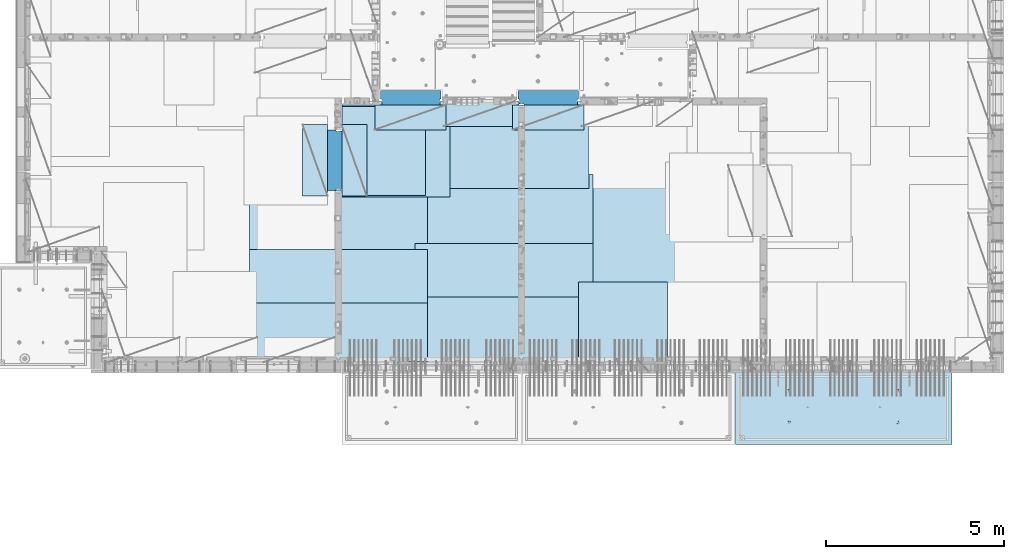
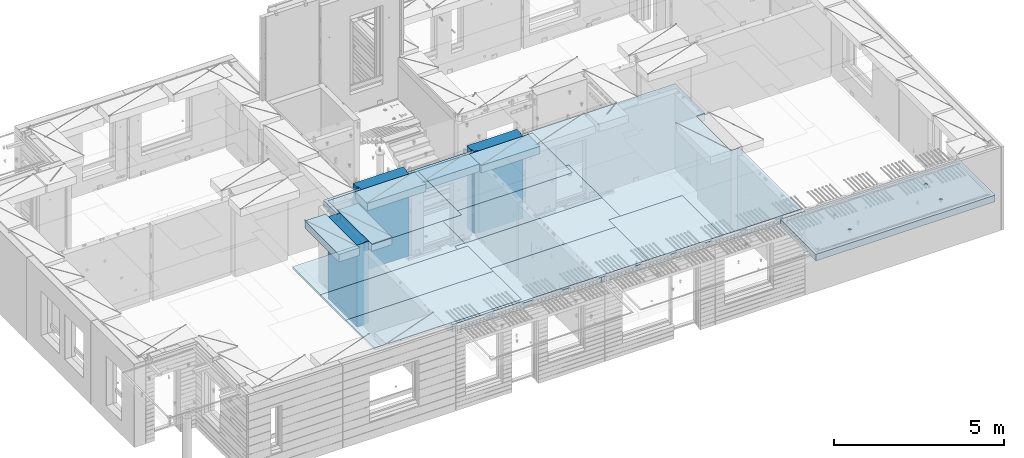
# One storey, part 202 of 352: 18 plates, 3 slabs, 19 elements without a shape of their own.
"""IFC2X3 building model written with IfcOpenShell, lengths in millimetres."""

import ifcopenshell
import ifcopenshell.guid

model = None  # the IFC model being written
_history = None  # IfcOwnerHistory: only IFC2X3 demands one
_inside = {}  # id of a spatial element -> (the spatial element, [elements in it])
_under = {}  # id of a project, library or spatial element -> (it, [spatial elements below it])
_declared = {}  # id of a project -> (the project, [libraries it declares])
_typed = {}  # id of a type object -> (the type object, [elements of that type])
_made_of = {}  # id of a material, layer set ... -> (it, [elements and type objects made of it])


def new_model(schema):
    """Start an empty IFC model of exactly this schema.

    Asked for "IFC4X3", IfcOpenShell would pick the latest addendum, in which some entities
    have other attributes; the version numbers below select the first issue.
    IFC2X3 requires an IfcOwnerHistory on every rooted entity: one is made here for all.
    """
    global model, _history
    if schema == "IFC4X3":
        model = ifcopenshell.file(schema_version=(4, 3, 0, 0))
    else:
        model = ifcopenshell.file(schema=schema)
    _inside.clear()
    _under.clear()
    _declared.clear()
    _typed.clear()
    _made_of.clear()
    _history = None
    if model.schema == "IFC2X3":
        org = make("IfcOrganization", Name="unknown")
        user = make(
            "IfcPersonAndOrganization",
            ThePerson=make("IfcPerson", FamilyName="unknown"),
            TheOrganization=org,
        )
        app = make(
            "IfcApplication",
            ApplicationDeveloper=org,
            Version="unknown",
            ApplicationFullName="unknown",
            ApplicationIdentifier="unknown",
        )
        _history = make(
            "IfcOwnerHistory",
            OwningUser=user,
            OwningApplication=app,
            ChangeAction="ADDED",
            CreationDate=0,
        )
    return model


def make(cls, **values):
    """One entity of the class cls with the attributes given. An attribute that is None is left unset."""
    return model.create_entity(
        cls, **{name: value for name, value in values.items() if value is not None}
    )


def rooted(cls, **values):
    """An entity with a GlobalId (a new one), such as an element, a storey or a relation."""
    return make(cls, GlobalId=ifcopenshell.guid.new(), OwnerHistory=_history, **values)


def si_unit(unit_type, name, prefix=None):
    """IfcSIUnit, for example si_unit("LENGTHUNIT", "METRE", prefix="MILLI")."""
    return make("IfcSIUnit", UnitType=unit_type, Prefix=prefix, Name=name)


def assignment(units):
    """IfcUnitAssignment: the units of a project."""
    return None if units is None else make("IfcUnitAssignment", Units=units)


def point(xyz):
    """IfcCartesianPoint."""
    return None if xyz is None else make("IfcCartesianPoint", Coordinates=xyz)


def direction(xyz):
    """IfcDirection."""
    return None if xyz is None else make("IfcDirection", DirectionRatios=xyz)


def frame(location, z_axis=None, x_axis=None):
    """IfcAxis2Placement3D, a coordinate frame: its origin and axes. An axis left out is left unset."""
    return make(
        "IfcAxis2Placement3D",
        Location=point(location),
        Axis=direction(z_axis),
        RefDirection=direction(x_axis),
    )


def origin_with_axes():
    """The frame at (0, 0, 0) with the z axis (0, 0, 1) and the x axis (1, 0, 0) written out."""
    return frame((0.0, 0.0, 0.0), z_axis=(0.0, 0.0, 1.0), x_axis=(1.0, 0.0, 0.0))


def place(relative_to, where):
    """IfcLocalPlacement: puts the frame where relative to a parent placement (None: the world)."""
    return make(
        "IfcLocalPlacement", PlacementRelTo=relative_to, RelativePlacement=where
    )


def context(
    kind, dimensions, precision=None, world=None, true_north=None, identifier=None
):
    """IfcGeometricRepresentationContext, for example the 3D "Model" context."""
    return make(
        "IfcGeometricRepresentationContext",
        ContextIdentifier=identifier,
        ContextType=kind,
        CoordinateSpaceDimension=dimensions,
        Precision=precision,
        WorldCoordinateSystem=world,
        TrueNorth=true_north,
    )


def subcontext(parent, identifier, kind, view, scale=None):
    """IfcGeometricRepresentationSubContext, for example "Body" below "Model"."""
    return make(
        "IfcGeometricRepresentationSubContext",
        ContextIdentifier=identifier,
        ContextType=kind,
        ParentContext=parent,
        TargetScale=scale,
        TargetView=view,
    )


def project(units=None, contexts=None):
    """IfcProject with its units and contexts."""
    return rooted(
        "IfcProject",
        Name="project",
        RepresentationContexts=contexts,
        UnitsInContext=assignment(units),
    )


def spatial(cls, under=None, at=None, **own):
    """A site, building, storey or space (cls), placed at a placement, below another one or the project."""
    s = rooted(cls, ObjectPlacement=at, **own)
    if under is not None:
        _under.setdefault(under.id(), (under, []))[1].append(s)
    return s


def faces_of(points, faces, orient=None, outer=None):
    """IfcFace entities. A face is a list of loops; a loop is a list of indices into points, from 0.

    orient and outer hold one flag for each loop. By default every Orientation is true, the
    first loop of a face is its IfcFaceOuterBound and the others are IfcFaceBound.
    """
    made = []
    for i, loops in enumerate(faces):
        bounds = []
        for j, loop in enumerate(loops):
            is_outer = j == 0 if outer is None else outer[i][j]
            bounds.append(
                make(
                    "IfcFaceOuterBound" if is_outer else "IfcFaceBound",
                    Bound=make("IfcPolyLoop", Polygon=[points[k] for k in loop]),
                    Orientation=True if orient is None else orient[i][j],
                )
            )
        made.append(make("IfcFace", Bounds=bounds))
    return made


def faceted_brep(points, faces, orient=None, outer=None, voids=None):
    """IfcFacetedBrep: a solid bounded by flat faces; with voids (closed shells), ...WithVoids."""
    shared = [point(p) for p in points]
    hull = make("IfcClosedShell", CfsFaces=faces_of(shared, faces, orient, outer))
    if voids is None:
        return make("IfcFacetedBrep", Outer=hull)
    return make(
        "IfcFacetedBrepWithVoids",
        Outer=hull,
        Voids=[
            make(cls, CfsFaces=faces_of(shared, fs, o, b)) for cls, fs, o, b in voids
        ],
    )


def shape(context_of_items, identifier, shape_type, items):
    """IfcShapeRepresentation: the items that make up one representation, for example the "Body"."""
    return make(
        "IfcShapeRepresentation",
        ContextOfItems=context_of_items,
        RepresentationIdentifier=identifier,
        RepresentationType=shape_type,
        Items=items,
    )


def material(Name=None, Category=None):
    """IfcMaterial."""
    return make("IfcMaterial", Name=Name, Category=Category)


def made_of(thing, what):
    """Note that an element or type object is made of a material, layer set ...; save() writes the relation."""
    if what is not None:
        _made_of.setdefault(what.id(), (what, []))[1].append(thing)
    return thing


def type_object(cls, material=None, **own):
    """A type object (cls), such as IfcWallType, which elements share."""
    return made_of(rooted(cls, **own), material)


def element(
    cls,
    number,
    at=None,
    inside=None,
    cuts=None,
    type_object=None,
    material=None,
    context=None,
    identifier="Body",
    shape_type=None,
    held_by="IfcProductDefinitionShape",
    body=None,
    shapes=None,
    **own,
):
    """One element of the class cls, such as IfcWall. Its Tag is "e" and its number.

    at: its placement. inside: the storey or other place that contains it. cuts: it is an
    opening in that element (IfcRelVoidsElement). A single representation is given by context,
    identifier, shape_type and body (its items); several are given by shapes. held_by: the class
    of the entity that holds the representations. save() writes the other relations.
    """
    e = rooted(cls, Tag="e%d" % number, ObjectPlacement=at, **own)
    if body is not None:
        shapes = [shape(context, identifier, shape_type, body)]
    if shapes is not None:
        e.Representation = make(held_by, Representations=shapes)
    if inside is not None:
        _inside.setdefault(inside.id(), (inside, []))[1].append(e)
    if cuts is not None:
        rooted(
            "IfcRelVoidsElement", RelatingBuildingElement=cuts, RelatedOpeningElement=e
        )
    if type_object is not None:
        _typed.setdefault(type_object.id(), (type_object, []))[1].append(e)
    return made_of(e, material)


def aggregate(whole, parts):
    """IfcRelAggregates: a whole, such as a stair, and the parts it consists of."""
    return rooted("IfcRelAggregates", RelatingObject=whole, RelatedObjects=parts)


def save(model, path):
    """Write the relations noted so far, then the file.

    IfcRelAggregates (storeys below a building ...), IfcRelContainedInSpatialStructure (elements
    in a storey), IfcRelDefinesByType, IfcRelAssociatesMaterial and IfcRelDeclares: one each for
    every whole, place, type object, material and project.
    """
    for whole, parts in _under.values():
        aggregate(whole, parts)
    for where, things in _inside.values():
        rooted(
            "IfcRelContainedInSpatialStructure",
            RelatedElements=things,
            RelatingStructure=where,
        )
    for kind, things in _typed.values():
        rooted("IfcRelDefinesByType", RelatedObjects=things, RelatingType=kind)
    for what, things in _made_of.values():
        rooted("IfcRelAssociatesMaterial", RelatedObjects=things, RelatingMaterial=what)
    for by, libraries in _declared.values():
        rooted("IfcRelDeclares", RelatingContext=by, RelatedDefinitions=libraries)
    model.write(path)


model = new_model("IFC2X3")

# Units and contexts
model_context = context("Model", 3, precision=1e-05, world=origin_with_axes())
body_context = subcontext(model_context, "Body", "Model", "MODEL_VIEW")
ifc_project = project(units=[si_unit("LENGTHUNIT", "METRE", prefix="MILLI"), si_unit("AREAUNIT", "SQUARE_METRE"), si_unit("VOLUMEUNIT", "CUBIC_METRE"), si_unit("MASSUNIT", "GRAM", prefix="KILO"), si_unit("TIMEUNIT", "SECOND"), si_unit("PLANEANGLEUNIT", "RADIAN"), si_unit("SOLIDANGLEUNIT", "STERADIAN"), si_unit("THERMODYNAMICTEMPERATUREUNIT", "DEGREE_CELSIUS"), si_unit("LUMINOUSINTENSITYUNIT", "LUMEN")], contexts=[model_context])

# Site, building, storey
site_placement = place(None, origin_with_axes())
site = spatial("IfcSite", under=ifc_project, at=site_placement, CompositionType="ELEMENT")
building_placement = place(site_placement, origin_with_axes())
building = spatial("IfcBuilding", under=site, at=building_placement, CompositionType="ELEMENT")
storey_placement = place(building_placement, origin_with_axes())
storey = spatial("IfcBuildingStorey", under=building, at=storey_placement, Name="6", CompositionType="ELEMENT", Elevation=0.0)

# Assembly, slab
assembly_1_placement = place(storey_placement, origin_with_axes())
assembly_1 = element("IfcElementAssembly", 1, at=assembly_1_placement, inside=storey, AssemblyPlace="NOTDEFINED", PredefinedType="REINFORCEMENT_UNIT")
ifc_material_1 = material(Name="CONCRETE/C30/37")
slab_type_1 = type_object("IfcSlabType", PredefinedType="NOTDEFINED")
slab_1_placement = place(assembly_1_placement, frame((21810.0, 7750.0, 99595.0), z_axis=(0.0, 1.0, 0.0), x_axis=(1.0, 0.0, 0.0)))
slab_1 = element("IfcSlab", 2, at=slab_1_placement, type_object=slab_type_1, material=ifc_material_1, PredefinedType="FLOOR", context=body_context, shape_type="Brep", body=[
    faceted_brep([(6500.0, -135.0, 5637.99963378906), (6500.0, 135.0, 5637.99963378906), (6500.0, 135.0, 5680.0), (6500.0, -135.0, 5680.0), (6800.0, -135.0, 5680.0), (6800.0, 135.0, 5680.0), (6800.0, -135.0, 3637.99963378906), (6800.0, 135.0, 3637.99963378906), (6500.0, 135.0, 3637.99963378906), (6500.0, -135.0, 3637.99963378906), (6800.0, -135.0, 0.0), (6800.0, 135.0, 0.0), (1.81898940354586e-12, -135.0, 1.81898940354586e-12), (1.81898940354586e-12, 135.0, 1.81898940354586e-12), (0.0, -135.0, 7330.0), (0.0, 135.0, 7330.0), (1569.99914550782, -135.0, 7330.0), (1569.99914550782, 135.0, 7330.0), (1569.99914550782, -135.0, 7430.0), (1569.99914550782, 135.0, 7430.0), (6800.0, -135.0, 7430.0), (6800.0, 135.0, 7430.0), (6500.0, 135.0, 3780.0), (6500.0, -135.0, 3780.0)], [[[0, 1, 2, 3]], [[4, 3, 2, 5]], [[6, 7, 8, 9]], [[10, 11, 7, 6]], [[10, 12, 13, 11]], [[12, 14, 15, 13]], [[16, 17, 15, 14]], [[18, 19, 17, 16]], [[20, 21, 19, 18]], [[21, 20, 4, 5]], [[1, 22, 8, 7, 11, 13, 15, 17, 19, 21, 5, 2]], [[23, 9, 8, 22, 1, 0]], [[20, 18, 16, 14, 12, 10, 6, 9, 23, 0, 3, 4]]]),
])

assembly_2_placement = place(storey_placement, origin_with_axes())
assembly_2 = element("IfcElementAssembly", 3, at=assembly_2_placement, inside=storey, AssemblyPlace="NOTDEFINED", PredefinedType="REINFORCEMENT_UNIT")
ifc_material_2 = material(Name="CONCRETE/C35/45")
slab_type_2 = type_object("IfcSlabType", PredefinedType="NOTDEFINED")
slab_2_placement = place(assembly_2_placement, frame((33909.9998568133, 7629.99655735226, 99590.0), z_axis=(-1.11800000013248e-06, -0.999999999999375, 0.0), x_axis=(-0.999999999999093, 1.34699999998405e-06, 0.0)))
slab_2 = element("IfcSlab", 4, at=slab_2_placement, type_object=slab_type_2, material=ifc_material_2, PredefinedType="FLOOR", context=body_context, shape_type="Brep", body=[
    faceted_brep([(4605.44993885855, -113.0, 552.448239707288), (4619.38834372919, -113.0, 559.550231553701), (4630.44991833371, -113.0, 570.61183115741), (4637.55187867931, -113.0, 584.55025207851), (4639.99903540509, -113.0, 600.001104562554), (4637.55184376039, -113.0, 615.451951515985), (4630.44985191398, -113.0, 629.39035638662), (4619.38825231027, -113.0, 640.451930991143), (4605.44983138917, -113.0, 647.553891336743), (4589.99897890513, -113.0, 650.001048062522), (4574.54813195169, -113.0, 647.553856417822), (4560.60972708106, -113.0, 640.451864571409), (4549.54815247653, -113.0, 629.390264967699), (4542.44619213093, -113.0, 615.451844046599), (4539.99903540516, -113.0, 600.000991562554), (4542.44622704986, -113.0, 584.550144609124), (4549.54821889627, -113.0, 570.61173973849), (4560.60981849998, -113.0, 559.550165133966), (4574.54823942108, -113.0, 552.448204788368), (4589.99909190512, -113.0, 550.001048062586), (4548.90468317908, -120.0, 570.144182560607), (4541.68970509875, -120.0, 584.304334781456), (4560.14226277649, -120.0, 558.906628360102), (4574.30243130315, -120.0, 551.691682281732), (4589.99909280399, -120.0, 549.205593517132), (4605.69574868622, -120.0, 551.691717756181), (4619.85590090707, -120.0, 558.906695836513), (4631.09345510757, -120.0, 570.14427543392), (4638.30840118594, -120.0, 584.304443960583), (4640.79448995055, -120.0, 600.001105461418), (4638.30836571149, -120.0, 615.697761343653), (4631.09338763116, -120.0, 629.857913564502), (4619.85580803376, -120.0, 641.095467765007), (4605.6956395071, -120.0, 648.310413843377), (4589.99897800626, -120.0, 650.796502607977), (4574.30232212402, -120.0, 648.310378368928), (4560.14216990317, -120.0, 641.095400288596), (4548.90461570267, -120.0, 629.85782069119), (4541.6896696243, -120.0, 615.697652164527), (4539.2035808597, -120.0, 600.000990663691), (0.000819232023786753, -120.0, 2085.00366210938), (6090.0009765625, -120.0, 2085.00366210938), (6090.0009765625, 120.0, 2085.00366210938), (0.000819232023786753, 120.0, 2085.00366210938), (6090.0, -120.0, 1.39971234602854e-09), (6090.0, 120.0, 1.39971234602854e-09), (-7.27595761418343e-12, -120.0, -9.09494701772928e-13), (-7.27595761418343e-12, 120.0, -9.09494701772928e-13), (1515.44893888152, -108.0, 1437.45474794476), (1529.38734375216, -108.0, 1444.55673979117), (1540.44891835668, -108.0, 1455.61833939488), (1547.55087870228, -108.0, 1469.55676031598), (1549.99803542806, -108.0, 1485.00761280002), (1547.55084378336, -108.0, 1500.45845975345), (1540.44885193695, -108.0, 1514.39686462409), (1529.38725233324, -108.0, 1525.45843922861), (1515.44883141214, -108.0, 1532.56039957421), (1499.99797892809, -108.0, 1535.00755629999), (1484.54713197466, -108.0, 1532.56036465529), (1470.60872710403, -108.0, 1525.45837280888), (1459.5471524995, -108.0, 1514.39677320517), (1452.44519215391, -108.0, 1500.45835228407), (1449.99803542813, -108.0, 1485.00749980002), (1452.44522707283, -108.0, 1469.55665284659), (1459.54721891924, -108.0, 1455.61824797596), (1470.60881852295, -108.0, 1444.55667337144), (1484.54723944405, -108.0, 1437.45471302584), (1499.99809192809, -108.0, 1435.00755630005), (1451.1483322995, -120.0, 1469.13526457059), (1448.63439906449, -120.0, 1485.00749825911), (1458.44401483263, -120.0, 1454.8167213853), (1469.80729442553, -120.0, 1443.45346747338), (1484.12585409903, -120.0, 1436.15781730018), (1499.998093469, -120.0, 1433.64391993642), (1515.87032715753, -120.0, 1436.15785317143), (1530.18887034281, -120.0, 1443.45353570456), (1541.55212425473, -120.0, 1454.81681529746), (1548.84777442794, -120.0, 1469.13537497096), (1551.3616717917, -120.0, 1485.00761434093), (1548.84773855669, -120.0, 1500.87984802946), (1541.55205602355, -120.0, 1515.19839121474), (1530.18877643065, -120.0, 1526.56164512666), (1515.87021675716, -120.0, 1533.85729529987), (1499.99797738718, -120.0, 1536.37119266363), (1484.12574369866, -120.0, 1533.85725942862), (1469.80720051337, -120.0, 1526.56157689548), (1458.44394660145, -120.0, 1515.19829730258), (1451.14829642824, -120.0, 1500.87973762909), (1515.44993893152, -113.0, 552.45474794532), (1529.38834380215, -113.0, 559.556739791733), (1540.44991840668, -113.0, 570.618339395443), (1547.55187875228, -113.0, 584.556760316543), (1549.99903547806, -113.0, 600.007612800588), (1547.55184383336, -113.0, 615.458459754018), (1540.44985198694, -113.0, 629.396864624653), (1529.38825238323, -113.0, 640.458439229175), (1515.44983146213, -113.0, 647.560399574775), (1499.99897897809, -113.0, 650.007556300556), (1484.54813202466, -113.0, 647.560364655855), (1470.60972715402, -113.0, 640.458372809442), (1459.5481525495, -113.0, 629.396773205733), (1452.4461922039, -113.0, 615.458352284632), (1449.99903547812, -113.0, 600.007499800588), (1452.44622712283, -113.0, 584.556652847157), (1459.54821896923, -113.0, 570.618247976523), (1470.60981857295, -113.0, 559.556673372), (1484.54823949404, -113.0, 552.4547130264), (1499.99909197809, -113.0, 550.007556300619), (1451.68970517172, -120.0, 584.310843019489), (1449.20358093267, -120.0, 600.007498901724), (1458.90468325205, -120.0, 570.15069079864), (1470.14226284945, -120.0, 558.913136598135), (1484.30243137612, -120.0, 551.698190519764), (1499.99909287695, -120.0, 549.212101755165), (1515.69574875919, -120.0, 551.698225994213), (1529.85590098004, -120.0, 558.913204074546), (1541.09345518054, -120.0, 570.150783671952), (1548.30840125891, -120.0, 584.310952198615), (1550.79449002351, -120.0, 600.007613699451), (1548.30836578447, -120.0, 615.704269581685), (1541.09338770413, -120.0, 629.864421802535), (1529.85580810672, -120.0, 641.10197600304), (1515.69563958006, -120.0, 648.31692208141), (1499.99897807923, -120.0, 650.803010846011), (1484.30232219699, -120.0, 648.316886606961), (1470.14216997614, -120.0, 641.101908526629), (1458.90461577564, -120.0, 629.864328929222), (1451.68966969727, -120.0, 615.704160402559), (4605.44893880856, -108.0, 1437.44823970672), (4619.38734367919, -108.0, 1444.55023155314), (4630.44891828372, -108.0, 1455.61183115685), (4637.55087862931, -108.0, 1469.55025207795), (4639.99803535509, -108.0, 1485.00110456199), (4637.55084371039, -108.0, 1500.45195151542), (4630.44885186398, -108.0, 1514.39035638605), (4619.38725226027, -108.0, 1525.45193099058), (4605.44883133917, -108.0, 1532.55389133618), (4589.99797885512, -108.0, 1535.00104806196), (4574.54713190169, -108.0, 1532.55385641726), (4560.60872703106, -108.0, 1525.45186457084), (4549.54715242653, -108.0, 1514.39026496713), (4542.44519208094, -108.0, 1500.45184404603), (4539.99803535516, -108.0, 1485.00099156199), (4542.44522699986, -108.0, 1469.55014460856), (4549.54721884627, -108.0, 1455.61173973792), (4560.60881844998, -108.0, 1444.5501651334), (4574.54723937108, -108.0, 1437.4482047878), (4589.99809185513, -108.0, 1435.00104806202), (4541.14833222653, -120.0, 1469.12875633256), (4538.63439899152, -120.0, 1485.00099002108), (4548.44401475967, -120.0, 1454.81021314727), (4559.80729435257, -120.0, 1443.44695923535), (4574.12585402606, -120.0, 1436.15130906214), (4589.99809339604, -120.0, 1433.63741169839), (4605.87032708456, -120.0, 1436.1513449334), (4620.18887026985, -120.0, 1443.44702746653), (4631.55212418177, -120.0, 1454.81030705943), (4638.84777435497, -120.0, 1469.12886673293), (4641.36167171873, -120.0, 1485.0011061029), (4638.84773848372, -120.0, 1500.87333979142), (4631.55205595059, -120.0, 1515.19188297671), (4620.18877635769, -120.0, 1526.55513688863), (4605.87021668419, -120.0, 1533.85078706184), (4589.99797731422, -120.0, 1536.36468442559), (4574.12574362569, -120.0, 1533.85075119058), (4559.80720044041, -120.0, 1526.55506865745), (4548.44394652849, -120.0, 1515.19178906455), (4541.14829635528, -120.0, 1500.87322939105)], [[[0, 1, 2, 3, 4, 5, 6, 7, 8, 9, 10, 11, 12, 13, 14, 15, 16, 17, 18, 19]], [[20, 16, 15, 21]], [[22, 17, 16, 20]], [[23, 18, 17, 22]], [[24, 19, 18, 23]], [[25, 0, 19, 24]], [[26, 1, 0, 25]], [[27, 2, 1, 26]], [[28, 3, 2, 27]], [[29, 4, 3, 28]], [[30, 5, 4, 29]], [[31, 6, 5, 30]], [[32, 7, 6, 31]], [[33, 8, 7, 32]], [[34, 9, 8, 33]], [[35, 10, 9, 34]], [[36, 11, 10, 35]], [[37, 12, 11, 36]], [[38, 13, 12, 37]], [[39, 14, 13, 38]], [[21, 15, 14, 39]], [[40, 41, 42, 43]], [[41, 44, 45, 42]], [[44, 46, 47, 45]], [[42, 45, 47, 43]], [[46, 40, 43, 47]], [[48, 49, 50, 51, 52, 53, 54, 55, 56, 57, 58, 59, 60, 61, 62, 63, 64, 65, 66, 67]], [[68, 63, 62, 69]], [[70, 64, 63, 68]], [[71, 65, 64, 70]], [[72, 66, 65, 71]], [[73, 67, 66, 72]], [[74, 48, 67, 73]], [[75, 49, 48, 74]], [[76, 50, 49, 75]], [[77, 51, 50, 76]], [[78, 52, 51, 77]], [[79, 53, 52, 78]], [[80, 54, 53, 79]], [[81, 55, 54, 80]], [[82, 56, 55, 81]], [[83, 57, 56, 82]], [[84, 58, 57, 83]], [[85, 59, 58, 84]], [[86, 60, 59, 85]], [[87, 61, 60, 86]], [[69, 62, 61, 87]], [[88, 89, 90, 91, 92, 93, 94, 95, 96, 97, 98, 99, 100, 101, 102, 103, 104, 105, 106, 107]], [[108, 103, 102, 109]], [[110, 104, 103, 108]], [[111, 105, 104, 110]], [[112, 106, 105, 111]], [[113, 107, 106, 112]], [[114, 88, 107, 113]], [[115, 89, 88, 114]], [[116, 90, 89, 115]], [[117, 91, 90, 116]], [[118, 92, 91, 117]], [[119, 93, 92, 118]], [[120, 94, 93, 119]], [[121, 95, 94, 120]], [[122, 96, 95, 121]], [[123, 97, 96, 122]], [[124, 98, 97, 123]], [[125, 99, 98, 124]], [[126, 100, 99, 125]], [[127, 101, 100, 126]], [[109, 102, 101, 127]], [[128, 129, 130, 131, 132, 133, 134, 135, 136, 137, 138, 139, 140, 141, 142, 143, 144, 145, 146, 147]], [[148, 143, 142, 149]], [[150, 144, 143, 148]], [[151, 145, 144, 150]], [[152, 146, 145, 151]], [[153, 147, 146, 152]], [[154, 128, 147, 153]], [[155, 129, 128, 154]], [[156, 130, 129, 155]], [[157, 131, 130, 156]], [[158, 132, 131, 157]], [[159, 133, 132, 158]], [[160, 134, 133, 159]], [[161, 135, 134, 160]], [[162, 136, 135, 161]], [[163, 137, 136, 162]], [[164, 138, 137, 163]], [[165, 139, 138, 164]], [[166, 140, 139, 165]], [[167, 141, 140, 166]], [[149, 142, 141, 167]], [[44, 41, 40, 46], [37, 36, 35, 34, 33, 32, 31, 30, 29, 28, 27, 26, 25, 24, 23, 22, 20, 21, 39, 38], [166, 165, 164, 163, 162, 161, 160, 159, 158, 157, 156, 155, 154, 153, 152, 151, 150, 148, 149, 167], [126, 125, 124, 123, 122, 121, 120, 119, 118, 117, 116, 115, 114, 113, 112, 111, 110, 108, 109, 127], [86, 85, 84, 83, 82, 81, 80, 79, 78, 77, 76, 75, 74, 73, 72, 71, 70, 68, 69, 87]]]),
])
aggregate(assembly_2, [slab_2])

# Assembly, plate
assembly_3_placement = place(storey_placement, origin_with_axes())
assembly_3 = element("IfcElementAssembly", 5, at=assembly_3_placement, inside=storey, Name="Steel Assembly", AssemblyPlace="NOTDEFINED", PredefinedType="NOTDEFINED")
ifc_material_3 = material()
plate_type_1 = type_object("IfcPlateType", PredefinedType="NOTDEFINED")
plate_1_placement = place(assembly_3_placement, frame((25910.0, 7750.0, 99695.1), z_axis=(-1.0, 3.00000001838171e-08, 0.0), x_axis=(0.0, 1.0, 0.0)))
plate_1 = element("IfcPlate", 6, at=plate_1_placement, type_object=plate_type_1, material=ifc_material_3, Name="1/2", context=body_context, shape_type="Brep", body=[
    faceted_brep([(0.0, -35.0, 0.0), (0.0, -35.0, 2500.0), (0.0, 35.0, 2500.0), (0.0, 35.0, 0.0), (2349.99951171875, -35.0, 2500.0), (2349.99951171875, 35.0, 2500.0), (2350.0, -35.0, 0.0), (2350.0, 35.0, 0.0)], [[[0, 1, 2, 3]], [[1, 4, 5, 2]], [[4, 6, 7, 5]], [[6, 0, 3, 7]], [[5, 7, 3, 2]], [[6, 4, 1, 0]]]),
])
aggregate(assembly_3, [plate_1])

assembly_4_placement = place(storey_placement, origin_with_axes())
assembly_4 = element("IfcElementAssembly", 7, at=assembly_4_placement, inside=storey, Name="Steel Assembly", AssemblyPlace="NOTDEFINED", PredefinedType="NOTDEFINED")
plate_2_placement = place(assembly_4_placement, frame((16759.9995320312, 12530.0000289158, 99695.1), z_axis=(0.0, 1.0, 0.0), x_axis=(1.0, 0.0, 0.0)))
plate_2 = element("IfcPlate", 8, at=plate_2_placement, type_object=plate_type_1, material=ifc_material_3, Name="1/2", context=body_context, shape_type="Brep", body=[
    faceted_brep([(0.0, -35.0, 0.0), (0.0, -35.0, 2500.0), (0.0, 35.0, 2500.0), (0.0, 35.0, 0.0), (2349.99951171875, -35.0, 2500.0), (2349.99951171875, 35.0, 2500.0), (2350.0, -35.0, 0.0), (2350.0, 35.0, 0.0)], [[[0, 1, 2, 3]], [[1, 4, 5, 2]], [[4, 6, 7, 5]], [[6, 0, 3, 7]], [[5, 7, 3, 2]], [[6, 4, 1, 0]]]),
])
aggregate(assembly_4, [plate_2])

assembly_5_placement = place(storey_placement, origin_with_axes())
assembly_5 = element("IfcElementAssembly", 9, at=assembly_5_placement, inside=storey, Name="Steel Assembly", AssemblyPlace="NOTDEFINED", PredefinedType="NOTDEFINED")
plate_3_placement = place(assembly_5_placement, frame((23810.0, 10780.0, 99695.1), z_axis=(-1.0, 3.00000001838171e-08, 0.0), x_axis=(0.0, 1.0, 0.0)))
plate_3 = element("IfcPlate", 10, at=plate_3_placement, type_object=plate_type_1, material=ifc_material_3, context=body_context, shape_type="Brep", body=[
    faceted_brep([(0.0, -35.0, 0.0), (0.0, -35.0, 5000.0), (0.0, 35.0, 5000.0), (0.0, 35.0, 0.0), (2349.99951171875, -35.0, 5000.0), (2349.99951171875, 35.0, 5000.0), (2350.0, -35.0, 0.0), (2350.0, 35.0, 0.0)], [[[0, 1, 2, 3]], [[1, 4, 5, 2]], [[4, 6, 7, 5]], [[6, 0, 3, 7]], [[5, 7, 3, 2]], [[6, 4, 1, 0]]]),
])
aggregate(assembly_5, [plate_3])

assembly_6_placement = place(storey_placement, origin_with_axes())
assembly_6 = element("IfcElementAssembly", 11, at=assembly_6_placement, inside=storey, Name="Steel Assembly", AssemblyPlace="NOTDEFINED", PredefinedType="NOTDEFINED")
plate_4_placement = place(assembly_6_placement, frame((23710.0, 12730.0, 99695.1), z_axis=(-1.0, 3.00000001838171e-08, 0.0), x_axis=(0.0, 1.0, 0.0)))
plate_4 = element("IfcPlate", 12, at=plate_4_placement, type_object=plate_type_1, material=ifc_material_3, context=body_context, shape_type="Brep", body=[
    faceted_brep([(0.0, -35.0, 0.0), (0.0, -35.0, 5000.0), (0.0, 35.0, 5000.0), (0.0, 35.0, 0.0), (2349.99951171875, -35.0, 5000.0), (2349.99951171875, 35.0, 5000.0), (2350.0, -35.0, 0.0), (2350.0, 35.0, 0.0)], [[[0, 1, 2, 3]], [[1, 4, 5, 2]], [[4, 6, 7, 5]], [[6, 0, 3, 7]], [[5, 7, 3, 2]], [[6, 4, 1, 0]]]),
])
aggregate(assembly_6, [plate_4])

assembly_7_placement = place(storey_placement, origin_with_axes())
assembly_7 = element("IfcElementAssembly", 13, at=assembly_7_placement, inside=storey, Name="Steel Assembly", AssemblyPlace="NOTDEFINED", PredefinedType="NOTDEFINED")
plate_5_placement = place(assembly_7_placement, frame((23810.0, 7750.0, 99695.1), z_axis=(-1.0, 3.00000001838171e-08, 0.0), x_axis=(0.0, 1.0, 0.0)))
plate_5 = element("IfcPlate", 14, at=plate_5_placement, type_object=plate_type_1, material=ifc_material_3, context=body_context, shape_type="Brep", body=[
    faceted_brep([(0.0, -35.0, 0.0), (0.0, -35.0, 5000.0), (0.0, 35.0, 5000.0), (0.0, 35.0, 0.0), (2349.99951171875, -35.0, 5000.0), (2349.99951171875, 35.0, 5000.0), (2350.0, -35.0, 0.0), (2350.0, 35.0, 0.0)], [[[0, 1, 2, 3]], [[1, 4, 5, 2]], [[4, 6, 7, 5]], [[6, 0, 3, 7]], [[5, 7, 3, 2]], [[6, 4, 1, 0]]]),
])
aggregate(assembly_7, [plate_5])

assembly_8_placement = place(storey_placement, origin_with_axes())
assembly_8 = element("IfcElementAssembly", 15, at=assembly_8_placement, inside=storey, Name="Steel Assembly", AssemblyPlace="NOTDEFINED", PredefinedType="NOTDEFINED")
plate_6_placement = place(assembly_8_placement, frame((19160.0, 10325.0, 99695.1), z_axis=(-1.0, 3.00000001838171e-08, 0.0), x_axis=(0.0, 1.0, 0.0)))
plate_6 = element("IfcPlate", 16, at=plate_6_placement, type_object=plate_type_1, material=ifc_material_3, context=body_context, shape_type="Brep", body=[
    faceted_brep([(0.0, -35.0, 0.0), (0.0, -35.0, 5000.0), (0.0, 35.0, 5000.0), (0.0, 35.0, 0.0), (2349.99951171875, -35.0, 5000.0), (2349.99951171875, 35.0, 5000.0), (2350.0, -35.0, 0.0), (2350.0, 35.0, 0.0)], [[[0, 1, 2, 3]], [[1, 4, 5, 2]], [[4, 6, 7, 5]], [[6, 0, 3, 7]], [[5, 7, 3, 2]], [[6, 4, 1, 0]]]),
])
aggregate(assembly_8, [plate_6])

assembly_9_placement = place(storey_placement, origin_with_axes())
assembly_9 = element("IfcElementAssembly", 17, at=assembly_9_placement, inside=storey, Name="Steel Assembly", AssemblyPlace="NOTDEFINED", PredefinedType="NOTDEFINED")
plate_7_placement = place(assembly_9_placement, frame((19160.0, 7850.0, 99695.1), z_axis=(-1.0, 3.00000001838171e-08, 0.0), x_axis=(0.0, 1.0, 0.0)))
plate_7 = element("IfcPlate", 18, at=plate_7_placement, type_object=plate_type_1, material=ifc_material_3, context=body_context, shape_type="Brep", body=[
    faceted_brep([(0.0, -35.0, 0.0), (0.0, -35.0, 5000.0), (0.0, 35.0, 5000.0), (0.0, 35.0, 0.0), (2349.99951171875, -35.0, 5000.0), (2349.99951171875, 35.0, 5000.0), (2350.0, -35.0, 0.0), (2350.0, 35.0, 0.0)], [[[0, 1, 2, 3]], [[1, 4, 5, 2]], [[4, 6, 7, 5]], [[6, 0, 3, 7]], [[5, 7, 3, 2]], [[6, 4, 1, 0]]]),
])
aggregate(assembly_9, [plate_7])

assembly_10_placement = place(storey_placement, origin_with_axes())
assembly_10 = element("IfcElementAssembly", 19, at=assembly_10_placement, inside=storey, Name="Steel Assembly", AssemblyPlace="NOTDEFINED", PredefinedType="NOTDEFINED")
plate_type_2 = type_object("IfcPlateType", PredefinedType="NOTDEFINED")
plate_8_placement = place(assembly_10_placement, frame((18810.0, 11180.0000122641, 99695.1000003815), z_axis=(1.0, 0.0, 0.0), x_axis=(0.0, -1.0, 0.0)))
plate_8 = element("IfcPlate", 20, at=plate_8_placement, type_object=plate_type_2, material=ifc_material_3, context=body_context, shape_type="Brep", body=[
    faceted_brep([(0.0, -35.0, 0.0), (0.0, -35.0, 5000.0), (0.0, 35.0, 5000.0), (0.0, 35.0, 0.0), (1499.99951171875, -35.0, 5000.0), (1499.99951171875, 35.0, 5000.0), (1500.0, -35.0, 0.0), (1500.0, 35.0, 0.0)], [[[0, 1, 2, 3]], [[1, 4, 5, 2]], [[4, 6, 7, 5]], [[6, 0, 3, 7]], [[5, 7, 3, 2]], [[6, 4, 1, 0]]]),
])
aggregate(assembly_10, [plate_8])

assembly_11_placement = place(storey_placement, origin_with_axes())
assembly_11 = element("IfcElementAssembly", 21, at=assembly_11_placement, inside=storey, Name="Steel Assembly", AssemblyPlace="NOTDEFINED", PredefinedType="NOTDEFINED")
plate_9_placement = place(assembly_11_placement, frame((14160.0, 11015.0000122641, 99695.1000003815), z_axis=(1.0, 0.0, 0.0), x_axis=(0.0, -1.0, 0.0)))
plate_9 = element("IfcPlate", 22, at=plate_9_placement, type_object=plate_type_2, material=ifc_material_3, context=body_context, shape_type="Brep", body=[
    faceted_brep([(0.0, -35.0, 0.0), (0.0, -35.0, 5000.0), (0.0, 35.0, 5000.0), (0.0, 35.0, 0.0), (1499.99951171875, -35.0, 5000.0), (1499.99951171875, 35.0, 5000.0), (1500.0, -35.0, 0.0), (1500.0, 35.0, 0.0)], [[[0, 1, 2, 3]], [[1, 4, 5, 2]], [[4, 6, 7, 5]], [[6, 0, 3, 7]], [[5, 7, 3, 2]], [[6, 4, 1, 0]]]),
])
aggregate(assembly_11, [plate_9])

assembly_12_placement = place(storey_placement, origin_with_axes())
assembly_12 = element("IfcElementAssembly", 23, at=assembly_12_placement, inside=storey, Name="Steel Assembly", AssemblyPlace="NOTDEFINED", PredefinedType="NOTDEFINED")
plate_type_3 = type_object("IfcPlateType", PredefinedType="NOTDEFINED")
plate_10_placement = place(assembly_12_placement, frame((16759.9998779297, 14525.0, 99595.3), z_axis=(1.0, 0.0, 0.0), x_axis=(0.0, -1.0, 0.0)))
plate_10 = element("IfcPlate", 24, at=plate_10_placement, type_object=plate_type_3, material=ifc_material_3, Name="RE1", context=body_context, shape_type="Brep", body=[
    faceted_brep([(1.81898940354586e-12, -135.0, 1.81898940354586e-12), (0.0, -135.0, 699.999999999996), (0.0, 135.0, 699.999999999996), (1.81898940354586e-12, 135.0, 1.81898940354586e-12), (1999.99951171875, -135.0, 699.999999999993), (1999.99951171875, 135.0, 699.999999999993), (2000.0, -135.0, -3.63797880709171e-12), (2000.0, 135.0, -3.63797880709171e-12)], [[[0, 1, 2, 3]], [[1, 4, 5, 2]], [[4, 6, 7, 5]], [[6, 0, 3, 7]], [[5, 7, 3, 2]], [[6, 4, 1, 0]]]),
])
aggregate(assembly_12, [plate_10])

assembly_13_placement = place(storey_placement, origin_with_axes())
assembly_13 = element("IfcElementAssembly", 25, at=assembly_13_placement, inside=storey, Name="Steel Assembly", AssemblyPlace="NOTDEFINED", PredefinedType="NOTDEFINED")
plate_11_placement = place(assembly_13_placement, frame((16359.7701220703, 12525.0, 99595.3), z_axis=(-1.0, 3.00000001838171e-08, 0.0), x_axis=(0.0, 1.0, 0.0)))
plate_11 = element("IfcPlate", 26, at=plate_11_placement, type_object=plate_type_3, material=ifc_material_3, Name="RE1", context=body_context, shape_type="Brep", body=[
    faceted_brep([(1.81898940354586e-12, -135.0, 1.81898940354586e-12), (0.0, -135.0, 699.999999999996), (0.0, 135.0, 699.999999999996), (1.81898940354586e-12, 135.0, 1.81898940354586e-12), (1999.99951171875, -135.0, 699.999999999993), (1999.99951171875, 135.0, 699.999999999993), (2000.0, -135.0, -3.63797880709171e-12), (2000.0, 135.0, -3.63797880709171e-12)], [[[0, 1, 2, 3]], [[1, 4, 5, 2]], [[4, 6, 7, 5]], [[6, 0, 3, 7]], [[5, 7, 3, 2]], [[6, 4, 1, 0]]]),
])
aggregate(assembly_13, [plate_11])

assembly_14_placement = place(storey_placement, origin_with_axes())
assembly_14 = element("IfcElementAssembly", 27, at=assembly_14_placement, inside=storey, Name="Steel Assembly", AssemblyPlace="NOTDEFINED", PredefinedType="NOTDEFINED")
plate_12_placement = place(assembly_14_placement, frame((21624.9991457614, 15179.9998963664, 99595.3), z_axis=(0.0, -1.0, 0.0), x_axis=(-1.0, 3.00000001838171e-08, 0.0)))
plate_12 = element("IfcPlate", 28, at=plate_12_placement, type_object=plate_type_3, material=ifc_material_3, Name="RE1", context=body_context, shape_type="Brep", body=[
    faceted_brep([(1.81898940354586e-12, -135.0, 1.81898940354586e-12), (0.0, -135.0, 699.999999999996), (0.0, 135.0, 699.999999999996), (1.81898940354586e-12, 135.0, 1.81898940354586e-12), (1999.99951171875, -135.0, 699.999999999993), (1999.99951171875, 135.0, 699.999999999993), (2000.0, -135.0, -3.63797880709171e-12), (2000.0, 135.0, -3.63797880709171e-12)], [[[0, 1, 2, 3]], [[1, 4, 5, 2]], [[4, 6, 7, 5]], [[6, 0, 3, 7]], [[5, 7, 3, 2]], [[6, 4, 1, 0]]]),
])
aggregate(assembly_14, [plate_12])

assembly_15_placement = place(storey_placement, origin_with_axes())
assembly_15 = element("IfcElementAssembly", 29, at=assembly_15_placement, inside=storey, Name="Steel Assembly", AssemblyPlace="NOTDEFINED", PredefinedType="NOTDEFINED")
plate_13_placement = place(assembly_15_placement, frame((23559.9991457614, 15079.9998963664, 99595.3), z_axis=(0.0, -1.0, 0.0), x_axis=(-1.0, 3.00000001838171e-08, 0.0)))
plate_13 = element("IfcPlate", 30, at=plate_13_placement, type_object=plate_type_3, material=ifc_material_3, Name="RE1", context=body_context, shape_type="Brep", body=[
    faceted_brep([(1.81898940354586e-12, -135.0, 1.81898940354586e-12), (0.0, -135.0, 699.999999999996), (0.0, 135.0, 699.999999999996), (1.81898940354586e-12, 135.0, 1.81898940354586e-12), (1999.99951171875, -135.0, 699.999999999993), (1999.99951171875, 135.0, 699.999999999993), (2000.0, -135.0, -3.63797880709171e-12), (2000.0, 135.0, -3.63797880709171e-12)], [[[0, 1, 2, 3]], [[1, 4, 5, 2]], [[4, 6, 7, 5]], [[6, 0, 3, 7]], [[5, 7, 3, 2]], [[6, 4, 1, 0]]]),
])
aggregate(assembly_15, [plate_13])

assembly_16_placement = place(storey_placement, origin_with_axes())
assembly_16 = element("IfcElementAssembly", 31, at=assembly_16_placement, inside=storey, Name="Steel Assembly", AssemblyPlace="NOTDEFINED", PredefinedType="NOTDEFINED")
plate_14_placement = place(assembly_16_placement, frame((19689.9991457614, 15079.9998963664, 99595.3), z_axis=(0.0, -1.0, 0.0), x_axis=(-1.0, 3.00000001838171e-08, 0.0)))
plate_14 = element("IfcPlate", 32, at=plate_14_placement, type_object=plate_type_3, material=ifc_material_3, Name="RE1", context=body_context, shape_type="Brep", body=[
    faceted_brep([(1.81898940354586e-12, -135.0, 1.81898940354586e-12), (0.0, -135.0, 699.999999999996), (0.0, 135.0, 699.999999999996), (1.81898940354586e-12, 135.0, 1.81898940354586e-12), (1999.99951171875, -135.0, 699.999999999993), (1999.99951171875, 135.0, 699.999999999993), (2000.0, -135.0, -3.63797880709171e-12), (2000.0, 135.0, -3.63797880709171e-12)], [[[0, 1, 2, 3]], [[1, 4, 5, 2]], [[4, 6, 7, 5]], [[6, 0, 3, 7]], [[5, 7, 3, 2]], [[6, 4, 1, 0]]]),
])
aggregate(assembly_16, [plate_14])

# Plate
plate_type_4 = type_object("IfcPlateType", PredefinedType="NOTDEFINED")
plate_15_placement = place(assembly_1_placement, frame((16760.0002457424, 12487.9997681111, 99725.45), z_axis=(0.0, 1.0, 0.0), x_axis=(1.0, 0.0, 0.0)))
plate_15 = element("IfcPlate", 33, at=plate_15_placement, type_object=plate_type_4, material=ifc_material_3, context=body_context, shape_type="Brep", body=[
    faceted_brep([(0.0, -5.0, 0.0), (0.0, -5.0, 2592.0), (0.0, 5.0, 2592.0), (0.0, 5.0, 0.0), (3041.99975585938, -5.0, 2592.0), (3041.99975585938, 5.0, 2592.0), (3041.99975585938, -5.0, 0.0), (3041.99975585938, 5.0, 0.0)], [[[0, 1, 2, 3]], [[1, 4, 5, 2]], [[4, 6, 7, 5]], [[6, 0, 3, 7]], [[5, 7, 3, 2]], [[6, 4, 1, 0]]]),
])

# Slab
slab_type_3 = type_object("IfcSlabType", PredefinedType="NOTDEFINED")
slab_3_placement = place(assembly_1_placement, frame((21810.0, 15180.0, 99595.0), z_axis=(0.0, -1.0, 0.0), x_axis=(-1.0, 3.00000001838171e-08, 0.0)))
slab_3 = element("IfcSlab", 34, at=slab_3_placement, type_object=slab_type_3, material=ifc_material_1, PredefinedType="FLOOR", context=body_context, shape_type="Brep", body=[
    faceted_brep([(2300.00087620694, -135.0, -2.78342304227408e-06), (2300.00087620694, 135.0, 0.0), (2300.00087620694, 135.0, 100.000233727807), (2300.00087620694, -135.0, 100.000233727807), (3920.000509996, 135.000000000015, 100.000233727807), (3920.000509996, -135.0, 100.000233727807), (3920.00085449219, -135.0, 0.0), (3920.00085449219, 135.0, 0.0), (5150.0, 135.0, 0.0), (5150.0, -135.0, 0.0), (5150.0, 135.0, 804.999923541527), (5150.0, -135.0, 804.999923541527), (5049.99975425761, 135.0, 804.999923541527), (5049.99975425761, -135.0, 804.999923541527), (5049.99975425761, 135.0, 2504.99992354153), (5049.99975425761, -135.0, 2504.99992354153), (5150.0, 135.0, 2504.99992354153), (5150.0, -135.0, 2504.99992354153), (5150.0, 135.0, 7330.0), (5150.0, -135.0, 7330.0), (5055.0, -135.0, 7330.0), (5055.0, 135.0, 7330.0), (5055.0, -135.0, 7430.0), (5055.0, 135.0, 7430.0), (0.0, -135.0, 7430.0), (0.0, 135.0, 7430.0), (70.0000000000036, -135.0, -8.47121555125341e-08), (3.63797880709171e-12, -135.0, 100.0), (70.0000000000036, -135.000000000015, 100.0), (70.0000000000036, 135.0, 0.0), (70.0000000000036, 135.0, 100.0), (0.0, 135.0, 100.0)], [[[0, 1, 2, 3]], [[3, 2, 4, 5]], [[6, 5, 4, 7]], [[8, 9, 6, 7]], [[9, 8, 10, 11]], [[11, 10, 12, 13]], [[13, 12, 14, 15]], [[15, 14, 16, 17]], [[18, 19, 17, 16]], [[20, 19, 18, 21]], [[22, 20, 21, 23]], [[24, 22, 23, 25]], [[26, 0, 3, 5, 6, 9, 11, 13, 15, 17, 19, 20, 22, 24, 27, 28]], [[1, 0, 26, 29]], [[25, 23, 21, 18, 16, 14, 12, 10, 8, 7, 4, 2, 1, 29, 30, 31]], [[26, 28, 30, 29]], [[27, 31, 30, 28]], [[24, 25, 31, 27]]]),
])

aggregate(assembly_1, [plate_15, slab_3, slab_1])

# Assembly, plate
assembly_17_placement = place(storey_placement, origin_with_axes())
assembly_17 = element("IfcElementAssembly", 35, at=assembly_17_placement, inside=storey, Name="Steel Assembly", AssemblyPlace="NOTDEFINED", PredefinedType="NOTDEFINED")
ifc_material_4 = material()
plate_type_5 = type_object("IfcPlateType", PredefinedType="NOTDEFINED")
plate_16_placement = place(assembly_17_placement, frame((17840.0, 15080.0, 98255.6000003815), z_axis=(0.0, 1.0, 0.0), x_axis=(1.0, 0.0, 0.0)))
plate_16 = element("IfcPlate", 36, at=plate_16_placement, type_object=plate_type_5, material=ifc_material_4, context=body_context, shape_type="Brep", body=[
    faceted_brep([(49.9991463160914, -1475.0, 156.999999814216), (49.9991455078125, -1216.89999961853, 156.999999999998), (49.9994900039455, -1216.89999961853, -0.000233727812883444), (49.9994832763732, -1475.0, 0.0), (0.0, -1475.0, 170.000000230655), (-0.00085392879191204, -1216.89999961853, 170.000000368096), (0.0, -1475.0, 400.0), (1699.99914550781, -1475.0, 400.0), (1699.99914550781, 1475.0, 400.0), (0.0, 1475.0, 400.0), (1699.99914550781, -1475.0, 169.999999999998), (1699.99914550781, 1475.0, 169.999999999998), (1669.99914550781, 1475.0, 156.999999999998), (1669.99914550781, 1475.0, 3.63797880709171e-12), (49.9994900039455, 1475.0, 0.0), (49.9991455078125, 1475.0, 156.999999999998), (0.0, 1475.0, 170.000000368096), (1669.99914550781, -1475.0, 156.999999999998), (1669.99914550781, -1475.0, 3.63797880709171e-12)], [[[0, 1, 2, 3]], [[4, 5, 1, 0]], [[6, 7, 8, 9]], [[8, 7, 10, 11]], [[9, 8, 11, 12, 13, 14, 15, 16]], [[10, 17, 12, 11]], [[18, 13, 12, 17]], [[14, 13, 18, 3, 2]], [[14, 2, 1, 15]], [[15, 1, 5, 16]], [[6, 9, 16, 5, 4]], [[18, 17, 10, 7, 6, 4, 0, 3]]]),
])
aggregate(assembly_17, [plate_16])

assembly_18_placement = place(storey_placement, origin_with_axes())
assembly_18 = element("IfcElementAssembly", 37, at=assembly_18_placement, inside=storey, Name="Steel Assembly", AssemblyPlace="NOTDEFINED", PredefinedType="NOTDEFINED")
plate_17_placement = place(assembly_18_placement, frame((21710.0, 15080.0, 98255.6000003815), z_axis=(0.0, 1.0, 0.0), x_axis=(1.0, 0.0, 0.0)))
plate_17 = element("IfcPlate", 38, at=plate_17_placement, type_object=plate_type_5, material=ifc_material_4, context=body_context, shape_type="Brep", body=[
    faceted_brep([(30.0, -1475.0, 29.9998239177003), (30.0, 1475.0, 29.9998239177003), (157.0, 1475.0, 29.9998239177003), (157.0, -1475.0, 29.9998239177003), (169.999923697669, -1475.0, 0.0), (169.999923697669, 1475.0, 0.0), (0.0, -1475.0, 170.000000230655), (0.0, 1475.0, 170.000000368096), (30.0, 1475.0, 156.999999999998), (30.0, -1475.0, 156.999999999998), (0.0, -1475.0, 400.0), (0.0, 1475.0, 400.0), (1699.99914550781, -1475.0, 400.0), (1699.99914550781, 1475.0, 400.0), (1699.99914550781, -1475.0, 169.999999999998), (1699.99914550781, 1475.0, 169.999999999998), (1669.99914550781, -1475.0, 156.999999999998), (1669.99914550781, 1475.0, 156.999999999998), (1669.99914550781, -1475.0, 3.63797880709171e-12), (1669.99914550781, 1475.0, 3.63797880709171e-12)], [[[0, 1, 2, 3]], [[4, 3, 2, 5]], [[6, 7, 8, 9]], [[10, 11, 7, 6]], [[10, 12, 13, 11]], [[13, 12, 14, 15]], [[14, 16, 17, 15]], [[18, 19, 17, 16]], [[19, 18, 4, 5]], [[1, 8, 7, 11, 13, 15, 17, 19, 5, 2]], [[9, 8, 1, 0]], [[18, 16, 14, 12, 10, 6, 9, 0, 3, 4]]]),
])
aggregate(assembly_18, [plate_17])

assembly_19_placement = place(storey_placement, origin_with_axes())
assembly_19 = element("IfcElementAssembly", 39, at=assembly_19_placement, inside=storey, Name="Steel Assembly", AssemblyPlace="NOTDEFINED", PredefinedType="NOTDEFINED")
plate_18_placement = place(assembly_19_placement, frame((16760.0, 12675.0, 98255.6000003815), z_axis=(-0.999999990476206, -0.000138013000065496, 0.0), x_axis=(-0.000138013000066464, 0.999999990476206, 0.0)))
plate_18 = element("IfcPlate", 40, at=plate_18_placement, type_object=plate_type_5, material=ifc_material_4, context=body_context, shape_type="Brep", body=[
    faceted_brep([(0.0234607562470046, -1475.0, 169.989834633274), (0.0234607562470046, 1475.0, 169.989834633274), (30.0, 1475.0, 156.999999999998), (30.0, -1475.0, 156.999999999998), (29.9999998430139, -1475.0, 0.0), (29.9999998430139, 1475.0, 0.0), (0.0552374608814716, -1475.0, 400.234619140623), (1700.05529785156, -1475.0, 399.999999999998), (1700.05529785156, 1475.0, 399.999999999998), (0.0552374608814716, 1475.0, 400.234619140623), (1700.0235408123, -1475.0, 169.775517151291), (1700.0235408123, 1475.0, 169.775517151291), (1670.00014467176, -1475.0, 156.765378823566), (1670.00014467176, 1475.0, 156.765378823566), (1670.00014467148, -1475.0, 1.13504938781261e-09), (1670.00014467148, 1475.0, 1.13504938781261e-09)], [[[0, 1, 2, 3]], [[4, 3, 2, 5]], [[6, 7, 8, 9]], [[8, 7, 10, 11]], [[12, 13, 11, 10]], [[14, 15, 13, 12]], [[15, 14, 4, 5]], [[1, 9, 8, 11, 13, 15, 5, 2]], [[6, 9, 1, 0]], [[14, 12, 10, 7, 6, 0, 3, 4]]]),
])
aggregate(assembly_19, [plate_18])

save(model, "model.ifc")
